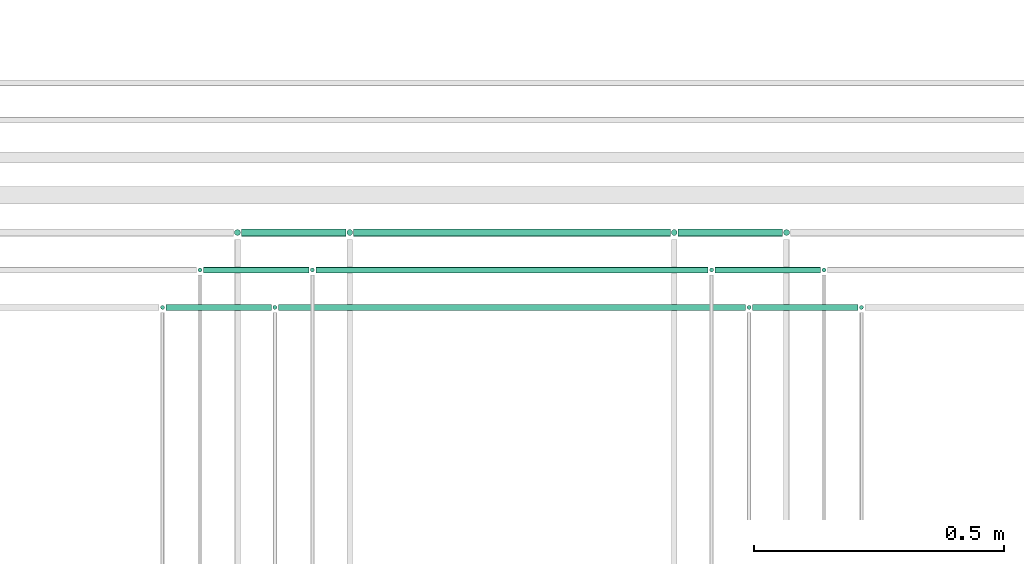
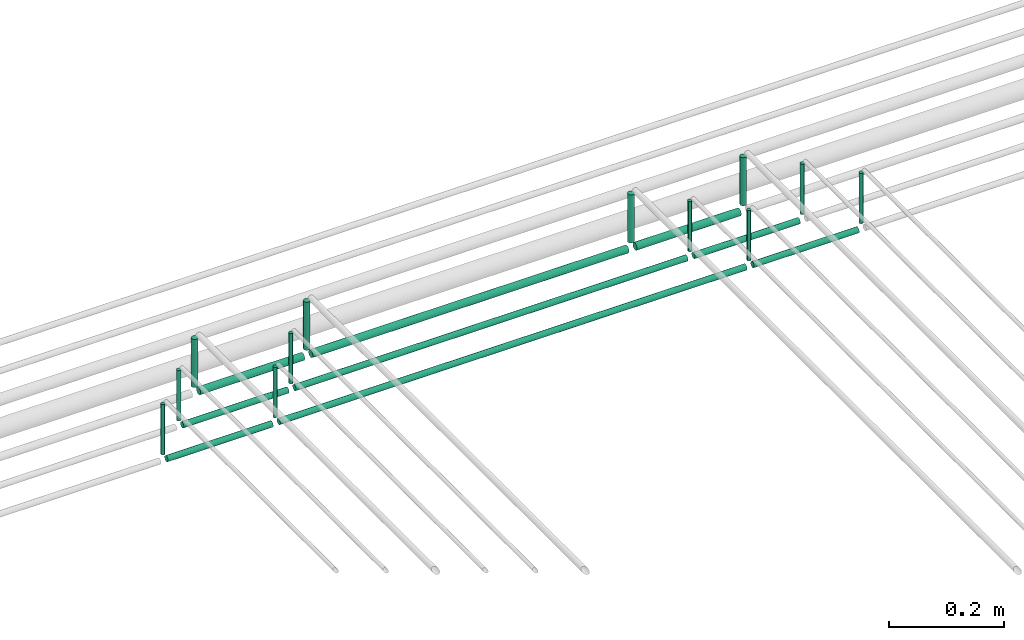
# One storey, part 203 of 331: 21 flow segments.
"""IFC2X3 building model written with IfcOpenShell, lengths in millimetres."""

from ifc_helpers import new_model, entity, si_unit, converted_unit, derived_unit, direction, frame, frame_2d, origin, origin_2d_with_axis, place, context, subcontext, project, spatial, circle, extrude, type_object, element, save


model = new_model("IFC2X3")

# Units and contexts
model_context = context("Model", 3, precision=0.01, world=origin(), true_north=direction((6.12303176911189e-17, 1.0)))
body_context = subcontext(model_context, "Body", "Model", "MODEL_VIEW")
ifc_project = project(units=[si_unit("LENGTHUNIT", "METRE", prefix="MILLI"), si_unit("AREAUNIT", "SQUARE_METRE"), si_unit("VOLUMEUNIT", "CUBIC_METRE"), converted_unit("PLANEANGLEUNIT", "DEGREE", entity("IfcRatioMeasure", 0.0174532925199433), si_unit("PLANEANGLEUNIT", "RADIAN"), dimensions=[0, 0, 0, 0, 0, 0, 0]), si_unit("MASSUNIT", "GRAM", prefix="KILO"), derived_unit("MASSDENSITYUNIT", [(si_unit("MASSUNIT", "GRAM", prefix="KILO"), 1), (si_unit("LENGTHUNIT", "METRE"), -3)]), derived_unit("MOMENTOFINERTIAUNIT", [(si_unit("LENGTHUNIT", "METRE"), 4)]), si_unit("TIMEUNIT", "SECOND"), si_unit("FREQUENCYUNIT", "HERTZ"), si_unit("THERMODYNAMICTEMPERATUREUNIT", "DEGREE_CELSIUS"), derived_unit("THERMALTRANSMITTANCEUNIT", [(si_unit("MASSUNIT", "GRAM", prefix="KILO"), 1), (si_unit("THERMODYNAMICTEMPERATUREUNIT", "KELVIN"), -1), (si_unit("TIMEUNIT", "SECOND"), -3)]), derived_unit("VOLUMETRICFLOWRATEUNIT", [(si_unit("LENGTHUNIT", "METRE"), 3), (si_unit("TIMEUNIT", "SECOND"), -1)]), derived_unit("MASSFLOWRATEUNIT", [(si_unit("MASSUNIT", "GRAM", prefix="KILO"), 1), (si_unit("TIMEUNIT", "SECOND"), -1)]), derived_unit("ROTATIONALFREQUENCYUNIT", [(si_unit("TIMEUNIT", "SECOND"), -1)]), si_unit("ELECTRICCURRENTUNIT", "AMPERE"), si_unit("ELECTRICVOLTAGEUNIT", "VOLT"), si_unit("POWERUNIT", "WATT"), si_unit("FORCEUNIT", "NEWTON", prefix="KILO"), si_unit("ILLUMINANCEUNIT", "LUX"), si_unit("LUMINOUSFLUXUNIT", "LUMEN"), si_unit("LUMINOUSINTENSITYUNIT", "CANDELA"), derived_unit("USERDEFINED", [(si_unit("MASSUNIT", "GRAM", prefix="KILO"), -1), (si_unit("LENGTHUNIT", "METRE"), -2), (si_unit("TIMEUNIT", "SECOND"), 3), (si_unit("LUMINOUSFLUXUNIT", "LUMEN"), 1)]), derived_unit("LINEARVELOCITYUNIT", [(si_unit("LENGTHUNIT", "METRE"), 1), (si_unit("TIMEUNIT", "SECOND"), -1)]), si_unit("PRESSUREUNIT", "PASCAL"), derived_unit("USERDEFINED", [(si_unit("LENGTHUNIT", "METRE"), -2), (si_unit("MASSUNIT", "GRAM", prefix="KILO"), 1), (si_unit("TIMEUNIT", "SECOND"), -2)]), derived_unit("LINEARFORCEUNIT", [(si_unit("MASSUNIT", "GRAM", prefix="KILO"), 1), (si_unit("LENGTHUNIT", "METRE"), 1), (si_unit("TIMEUNIT", "SECOND"), -2), (si_unit("LENGTHUNIT", "METRE"), -1)]), derived_unit("PLANARFORCEUNIT", [(si_unit("MASSUNIT", "GRAM", prefix="KILO"), 1), (si_unit("LENGTHUNIT", "METRE"), 1), (si_unit("TIMEUNIT", "SECOND"), -2), (si_unit("LENGTHUNIT", "METRE"), -2)])], contexts=[model_context])

# Site, building, storey
site_placement = place(None, frame((0.0, -0.00077364408347762, 0.0)))
site = spatial("IfcSite", under=ifc_project, at=site_placement, CompositionType="ELEMENT")
building_placement = place(site_placement, origin())
building = spatial("IfcBuilding", under=site, at=building_placement, CompositionType="ELEMENT")
storey_placement = place(building_placement, origin())
storey = spatial("IfcBuildingStorey", under=building, at=storey_placement, CompositionType="ELEMENT", Elevation=0.0)

# Flow segments
pipe_segment_type = type_object("IfcPipeSegmentType", PredefinedType="NOTDEFINED")
flow_segment_1_placement = place(storey_placement, frame((52812.4468045266, 9542.40472776406, 18464.0)))
element("IfcFlowSegment", 1, at=flow_segment_1_placement, inside=storey, type_object=pipe_segment_type, context=body_context, shape_type="SweptSolid", body=[
    extrude(circle(Radius=6.0, at=origin_2d_with_axis()), frame((7.59527223591454, 7.59527223591562, 0.0), z_axis=(0.0, 0.0, 1.0), x_axis=(-1.0, 0.0, 0.0)), (0.0, 0.0, 1.0), 101.999999999996),
])
flow_segment_2_placement = place(storey_placement, frame((53037.4468045266, 9542.40472776406, 18464.0)))
element("IfcFlowSegment", 2, at=flow_segment_2_placement, inside=storey, type_object=pipe_segment_type, context=body_context, shape_type="SweptSolid", body=[
    extrude(circle(Radius=6.0, at=origin_2d_with_axis()), frame((7.59527223591454, 7.59527223591562, 0.0), z_axis=(0.0, 0.0, 1.0), x_axis=(-1.0, 0.0, 0.0)), (0.0, 0.0, 1.0), 102.000000000035),
])
flow_segment_3_placement = place(storey_placement, frame((52828.0420767625, 9540.90472776406, 18440.9047277641)))
element("IfcFlowSegment", 3, at=flow_segment_3_placement, inside=storey, type_object=pipe_segment_type, context=body_context, shape_type="SweptSolid", body=[
    extrude(circle(Radius=7.5, at=origin_2d_with_axis()), frame((0.0, 9.09527223591636, 9.09527223591636), z_axis=(1.0, 0.0, 0.0), x_axis=(0.0, -1.0, 0.0)), (0.0, 0.0, 1.0), 209.000000000004),
])
flow_segment_4_placement = place(storey_placement, frame((53687.5706481368, 9542.40472776406, 18464.0)))
element("IfcFlowSegment", 4, at=flow_segment_4_placement, inside=storey, type_object=pipe_segment_type, context=body_context, shape_type="SweptSolid", body=[
    extrude(circle(Radius=6.0, at=origin_2d_with_axis()), frame((7.59527223591454, 7.59527223591562, 0.0), z_axis=(0.0, 0.0, 1.0), x_axis=(-1.0, 0.0, 0.0)), (0.0, 0.0, 1.0), 102.000000000027),
])
flow_segment_5_placement = place(storey_placement, frame((53053.0420767625, 9540.90472776406, 18440.9047277641)))
element("IfcFlowSegment", 5, at=flow_segment_5_placement, inside=storey, type_object=pipe_segment_type, context=body_context, shape_type="SweptSolid", body=[
    extrude(circle(Radius=7.5, at=origin_2d_with_axis()), frame((0.0, 9.09527223591636, 9.09527223591636), z_axis=(1.0, 0.0, 0.0), x_axis=(0.0, -1.0, 0.0)), (0.0, 0.0, 1.0), 634.123843610235),
])
flow_segment_6_placement = place(storey_placement, frame((53912.5706481368, 9542.40472776406, 18464.0)))
element("IfcFlowSegment", 6, at=flow_segment_6_placement, inside=storey, type_object=pipe_segment_type, context=body_context, shape_type="SweptSolid", body=[
    extrude(circle(Radius=6.0, at=frame_2d((0.0, 1.08286712929839e-12), x_axis=(1.0, 0.0))), frame((7.59527223591454, 7.5952722359167, 0.0), z_axis=(0.0, 0.0, 1.0), x_axis=(-1.0, 0.0, 0.0)), (0.0, 0.0, 1.0), 101.99999999997),
])
flow_segment_7_placement = place(storey_placement, frame((53703.1659203727, 9540.90472776406, 18440.9047277641)))
element("IfcFlowSegment", 7, at=flow_segment_7_placement, inside=storey, type_object=pipe_segment_type, context=body_context, shape_type="SweptSolid", body=[
    extrude(circle(Radius=7.5, at=origin_2d_with_axis()), frame((0.0, 9.09527223591636, 9.09527223591636), z_axis=(1.0, 0.0, 0.0), x_axis=(0.0, -1.0, 0.0)), (0.0, 0.0, 1.0), 209.000000000004),
])
flow_segment_8_placement = place(storey_placement, frame((52739.4468045266, 9469.404727764, 18463.0)))
element("IfcFlowSegment", 8, at=flow_segment_8_placement, inside=storey, type_object=pipe_segment_type, context=body_context, shape_type="SweptSolid", body=[
    extrude(circle(Radius=4.0, at=origin_2d_with_axis()), frame((5.59527223591499, 5.59527223591607, 0.0), z_axis=(0.0, 0.0, 1.0), x_axis=(-1.0, 0.0, 0.0)), (0.0, 0.0, 1.0), 106.999999999909),
])
flow_segment_9_placement = place(storey_placement, frame((52752.0420767625, 9467.404727764, 18442.4047277642)))
element("IfcFlowSegment", 9, at=flow_segment_9_placement, inside=storey, type_object=pipe_segment_type, context=body_context, shape_type="SweptSolid", body=[
    extrude(circle(Radius=6.0, at=frame_2d((0.0, -2.16573425859679e-12), x_axis=(1.0, 0.0))), frame((0.0, 7.59527223591562, 7.59527223591887), z_axis=(1.0, 0.0, 0.0), x_axis=(0.0, 1.0, 0.0)), (0.0, 0.0, 1.0), 211.000000000004),
])
flow_segment_10_placement = place(storey_placement, frame((52964.4468045266, 9469.404727764, 18463.0)))
element("IfcFlowSegment", 10, at=flow_segment_10_placement, inside=storey, type_object=pipe_segment_type, context=body_context, shape_type="SweptSolid", body=[
    extrude(circle(Radius=4.0, at=origin_2d_with_axis()), frame((5.59527223591499, 5.59527223591607, 0.0), z_axis=(0.0, 0.0, 1.0), x_axis=(-1.0, 0.0, 0.0)), (0.0, 0.0, 1.0), 106.999999999963),
])
flow_segment_11_placement = place(storey_placement, frame((52977.0420767625, 9467.404727764, 18442.4047277642)))
element("IfcFlowSegment", 11, at=flow_segment_11_placement, inside=storey, type_object=pipe_segment_type, context=body_context, shape_type="SweptSolid", body=[
    extrude(circle(Radius=6.0, at=frame_2d((0.0, -2.16573425859679e-12), x_axis=(1.0, 0.0))), frame((0.0, 7.59527223591562, 7.59527223591887), z_axis=(1.0, 0.0, 0.0), x_axis=(0.0, 1.0, 0.0)), (0.0, 0.0, 1.0), 786.123843610235),
])
flow_segment_12_placement = place(storey_placement, frame((53764.5706481368, 9469.404727764, 18463.0)))
element("IfcFlowSegment", 12, at=flow_segment_12_placement, inside=storey, type_object=pipe_segment_type, context=body_context, shape_type="SweptSolid", body=[
    extrude(circle(Radius=4.0, at=origin_2d_with_axis()), frame((5.59527223591499, 5.59527223591607, 0.0), z_axis=(0.0, 0.0, 1.0), x_axis=(-1.0, 0.0, 0.0)), (0.0, 0.0, 1.0), 106.999999999963),
])
flow_segment_13_placement = place(storey_placement, frame((53777.1659203728, 9467.404727764, 18442.4047277642)))
element("IfcFlowSegment", 13, at=flow_segment_13_placement, inside=storey, type_object=pipe_segment_type, context=body_context, shape_type="SweptSolid", body=[
    extrude(circle(Radius=6.0, at=frame_2d((0.0, -2.16573425859679e-12), x_axis=(1.0, 0.0))), frame((0.0, 7.59527223591562, 7.59527223591887), z_axis=(1.0, 0.0, 0.0), x_axis=(0.0, 1.0, 0.0)), (0.0, 0.0, 1.0), 211.000000000004),
])
flow_segment_14_placement = place(storey_placement, frame((53989.5706481368, 9469.404727764, 18463.0)))
element("IfcFlowSegment", 14, at=flow_segment_14_placement, inside=storey, type_object=pipe_segment_type, context=body_context, shape_type="SweptSolid", body=[
    extrude(circle(Radius=4.0, at=origin_2d_with_axis()), frame((5.59527223591499, 5.59527223591607, 0.0), z_axis=(0.0, 0.0, 1.0), x_axis=(-1.0, 0.0, 0.0)), (0.0, 0.0, 1.0), 106.999999999909),
])
flow_segment_15_placement = place(storey_placement, frame((52664.4468045266, 9394.404727764, 18463.0)))
element("IfcFlowSegment", 15, at=flow_segment_15_placement, inside=storey, type_object=pipe_segment_type, context=body_context, shape_type="SweptSolid", body=[
    extrude(circle(Radius=4.0, at=frame_2d((0.0, 1.08286712929839e-12), x_axis=(1.0, 0.0))), frame((5.59527223591499, 5.59527223591716, 0.0), z_axis=(0.0, 0.0, 1.0), x_axis=(-1.0, 0.0, 0.0)), (0.0, 0.0, 1.0), 106.999999999909),
])
flow_segment_16_placement = place(storey_placement, frame((52677.0420767625, 9392.404727764, 18442.4047277642)))
element("IfcFlowSegment", 16, at=flow_segment_16_placement, inside=storey, type_object=pipe_segment_type, context=body_context, shape_type="SweptSolid", body=[
    extrude(circle(Radius=6.0, at=origin_2d_with_axis()), frame((0.0, 7.59527223591562, 7.5952722359167), z_axis=(1.0, 0.0, 0.0), x_axis=(0.0, 1.0, 0.0)), (0.0, 0.0, 1.0), 211.000000000021),
])
flow_segment_17_placement = place(storey_placement, frame((52889.4468045266, 9394.404727764, 18463.0)))
element("IfcFlowSegment", 17, at=flow_segment_17_placement, inside=storey, type_object=pipe_segment_type, context=body_context, shape_type="SweptSolid", body=[
    extrude(circle(Radius=4.0, at=frame_2d((0.0, 1.08286712929839e-12), x_axis=(1.0, 0.0))), frame((5.59527223591499, 5.59527223591716, 0.0), z_axis=(0.0, 0.0, 1.0), x_axis=(-1.0, 0.0, 0.0)), (0.0, 0.0, 1.0), 106.999999999926),
])
flow_segment_18_placement = place(storey_placement, frame((52902.0420767625, 9392.404727764, 18442.4047277642)))
element("IfcFlowSegment", 18, at=flow_segment_18_placement, inside=storey, type_object=pipe_segment_type, context=body_context, shape_type="SweptSolid", body=[
    extrude(circle(Radius=6.0, at=origin_2d_with_axis()), frame((0.0, 7.59527223591562, 7.5952722359167), z_axis=(1.0, 0.0, 0.0), x_axis=(0.0, 1.0, 0.0)), (0.0, 0.0, 1.0), 936.123843610218),
])
flow_segment_19_placement = place(storey_placement, frame((53839.5706481368, 9394.404727764, 18463.0)))
element("IfcFlowSegment", 19, at=flow_segment_19_placement, inside=storey, type_object=pipe_segment_type, context=body_context, shape_type="SweptSolid", body=[
    extrude(circle(Radius=4.0, at=frame_2d((0.0, 1.08286712929839e-12), x_axis=(1.0, 0.0))), frame((5.59527223591499, 5.59527223591716, 0.0), z_axis=(0.0, 0.0, 1.0), x_axis=(-1.0, 0.0, 0.0)), (0.0, 0.0, 1.0), 106.999999999926),
])
flow_segment_20_placement = place(storey_placement, frame((53852.1659203728, 9392.404727764, 18442.4047277642)))
element("IfcFlowSegment", 20, at=flow_segment_20_placement, inside=storey, type_object=pipe_segment_type, context=body_context, shape_type="SweptSolid", body=[
    extrude(circle(Radius=6.0, at=origin_2d_with_axis()), frame((0.0, 7.59527223591562, 7.5952722359167), z_axis=(1.0, 0.0, 0.0), x_axis=(0.0, 1.0, 0.0)), (0.0, 0.0, 1.0), 211.000000000021),
])
flow_segment_21_placement = place(storey_placement, frame((54064.5706481369, 9394.404727764, 18463.0)))
element("IfcFlowSegment", 21, at=flow_segment_21_placement, inside=storey, type_object=pipe_segment_type, context=body_context, shape_type="SweptSolid", body=[
    extrude(circle(Radius=4.0, at=frame_2d((0.0, 1.08286712929839e-12), x_axis=(1.0, 0.0))), frame((5.59527223591499, 5.59527223591716, 0.0), z_axis=(0.0, 0.0, 1.0), x_axis=(-1.0, 0.0, 0.0)), (0.0, 0.0, 1.0), 106.999999999909),
])

save(model, "model.ifc")
